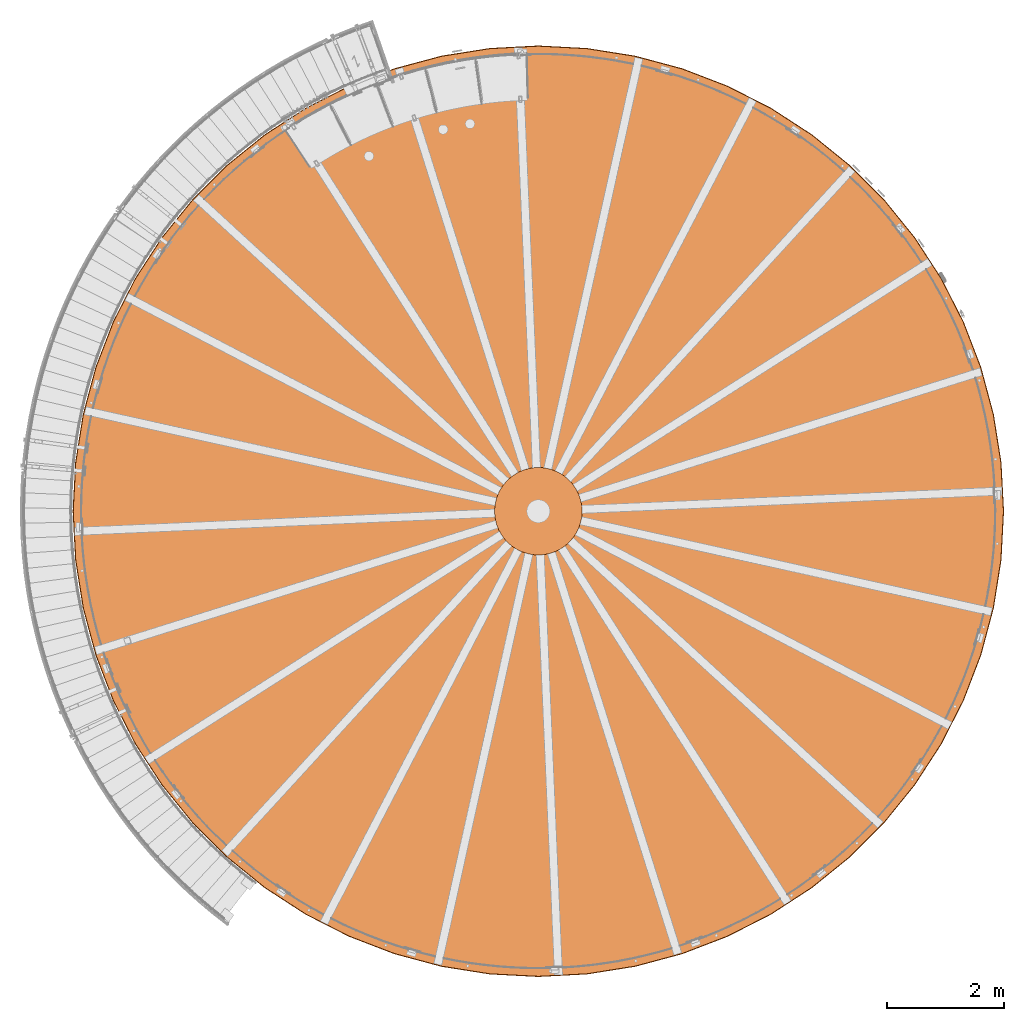
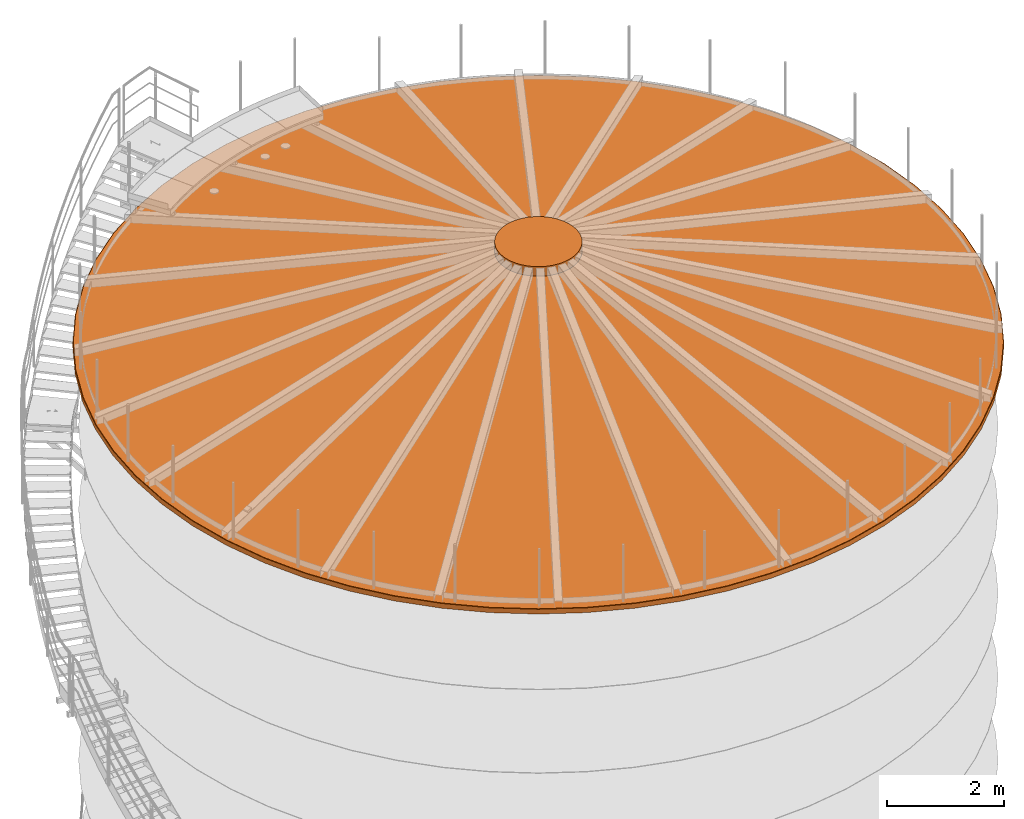
# One storey, part 21 of 126: 3 proxies.
"""IFC2X3 building model written with IfcOpenShell, lengths in millimetres."""

from ifc_helpers import new_model, si_unit, origin, origin_with_axes, place, context, project, spatial, faceted_brep, material, element, save


model = new_model("IFC2X3")

# Units and contexts
context_of_model_1 = context(None, 3, precision=0.1, world=origin())
context_of_model_2 = context(None, 3, precision=0.1, world=origin())
ifc_project = project(units=[si_unit("LENGTHUNIT", "METRE", prefix="MILLI"), si_unit("AREAUNIT", "SQUARE_METRE", prefix="CENTI"), si_unit("VOLUMEUNIT", "CUBIC_METRE", prefix="CENTI"), si_unit("MASSUNIT", "GRAM", prefix="KILO")], contexts=[context_of_model_1, context_of_model_2])

# Site, building, storey
site_placement = place(None, origin_with_axes())
site = spatial("IfcSite", under=ifc_project, at=site_placement, CompositionType="ELEMENT")
building_placement = place(site_placement, origin_with_axes())
building = spatial("IfcBuilding", under=site, at=building_placement, CompositionType="ELEMENT")
storey_placement = place(building_placement, origin_with_axes())
storey = spatial("IfcBuildingStorey", under=building, at=storey_placement, CompositionType="ELEMENT")

# Proxies
ifc_material = material(Name="STAHL")
proxy_1_placement = place(storey_placement, origin_with_axes())
element("IfcBuildingElementProxy", 1, at=proxy_1_placement, inside=storey, material=ifc_material, Name="profile", context=context_of_model_2, shape_type="Brep", body=[
    faceted_brep([(4017.5, 14911.6, 10506.0), (4761.3, 15290.5, 10506.0), (4761.3, 15290.5, 10494.0), (4017.5, 14911.6, 10494.0), (3317.4, 14456.9, 10506.0), (3317.4, 14456.9, 10494.0), (15936.3, 8838.6, 10506.0), (15980.0, 8005.0, 10506.0), (15980.0, 8005.0, 10494.0), (15936.3, 8838.6, 10494.0), (2668.7, 13931.6, 10506.0), (2668.7, 13931.6, 10494.0), (15805.7, 9663.1, 10506.0), (15805.7, 9663.1, 10494.0), (2078.4, 13341.3, 10506.0), (2078.4, 13341.3, 10494.0), (15589.7, 10469.4, 10506.0), (15589.7, 10469.4, 10494.0), (1553.1, 12692.6, 10506.0), (1553.1, 12692.6, 10494.0), (15290.5, 11248.7, 10506.0), (15290.5, 11248.7, 10494.0), (1098.4, 11992.5, 10506.0), (1098.4, 11992.5, 10494.0), (14911.6, 11992.5, 10506.0), (14911.6, 11992.5, 10494.0), (719.5, 11248.7, 10506.0), (719.5, 11248.7, 10494.0), (14456.9, 12692.6, 10506.0), (14456.9, 12692.6, 10494.0), (420.3, 10469.4, 10506.0), (420.3, 10469.4, 10494.0), (13931.6, 13341.3, 10506.0), (13931.6, 13341.3, 10494.0), (204.3, 9663.1, 10506.0), (204.3, 9663.1, 10494.0), (13341.3, 13931.6, 10506.0), (13341.3, 13931.6, 10494.0), (73.7, 8838.6, 10506.0), (73.7, 8838.6, 10494.0), (12692.6, 14456.9, 10506.0), (12692.6, 14456.9, 10494.0), (30.0, 8005.0, 10506.0), (30.0, 8005.0, 10494.0), (11992.5, 14911.6, 10506.0), (11992.5, 14911.6, 10494.0), (11248.7, 15290.5, 10506.0), (11248.7, 15290.5, 10494.0), (10469.4, 15589.7, 10506.0), (10469.4, 15589.7, 10494.0), (9663.1, 15805.7, 10506.0), (9663.1, 15805.7, 10494.0), (8838.6, 15936.3, 10506.0), (8838.6, 15936.3, 10494.0), (8005.0, 15980.0, 10506.0), (8005.0, 15980.0, 10494.0), (7171.4, 15936.3, 10506.0), (7171.4, 15936.3, 10494.0), (6346.9, 15805.7, 10506.0), (6346.9, 15805.7, 10494.0), (5540.6, 15589.7, 10506.0), (5540.6, 15589.7, 10494.0), (11907.5, 1245.7, 10506.0), (11907.5, 1245.7, 10494.0), (11179.6, 874.8, 10494.0), (11179.6, 874.8, 10506.0), (12592.7, 1690.6, 10506.0), (12592.7, 1690.6, 10494.0), (242.8, 7189.2, 10506.0), (242.8, 7189.2, 10494.0), (200.0, 8005.0, 10494.0), (200.0, 8005.0, 10506.0), (13227.6, 2204.8, 10506.0), (13227.6, 2204.8, 10494.0), (370.6, 6382.2, 10506.0), (370.6, 6382.2, 10494.0), (13805.2, 2782.4, 10506.0), (13805.2, 2782.4, 10494.0), (582.0, 5593.1, 10506.0), (582.0, 5593.1, 10494.0), (874.8, 4830.4, 10506.0), (874.8, 4830.4, 10494.0), (14319.4, 3417.3, 10506.0), (14319.4, 3417.3, 10494.0), (14764.3, 4102.5, 10506.0), (14764.3, 4102.5, 10494.0), (1245.7, 4102.5, 10506.0), (1245.7, 4102.5, 10494.0), (1690.6, 3417.3, 10506.0), (1690.6, 3417.3, 10494.0), (15135.2, 4830.4, 10506.0), (15135.2, 4830.4, 10494.0), (15428.0, 5593.1, 10506.0), (15428.0, 5593.1, 10494.0), (2204.8, 2782.4, 10506.0), (2204.8, 2782.4, 10494.0), (15639.4, 6382.2, 10506.0), (15639.4, 6382.2, 10494.0), (2782.4, 2204.8, 10506.0), (2782.4, 2204.8, 10494.0), (15767.2, 7189.2, 10506.0), (15767.2, 7189.2, 10494.0), (3417.3, 1690.6, 10506.0), (3417.3, 1690.6, 10494.0), (15810.0, 8005.0, 10506.0), (15810.0, 8005.0, 10494.0), (4102.5, 1245.7, 10506.0), (4102.5, 1245.7, 10494.0), (4830.4, 874.8, 10506.0), (4830.4, 874.8, 10494.0), (5593.1, 582.0, 10506.0), (5593.1, 582.0, 10494.0), (6382.2, 370.6, 10506.0), (6382.2, 370.6, 10494.0), (7189.2, 242.8, 10506.0), (7189.2, 242.8, 10494.0), (8005.0, 200.0, 10506.0), (8005.0, 200.0, 10494.0), (8820.8, 242.8, 10506.0), (8820.8, 242.8, 10494.0), (9627.8, 370.6, 10506.0), (9627.8, 370.6, 10494.0), (10416.9, 582.0, 10506.0), (10416.9, 582.0, 10494.0), (8005.0, 30.0, 10506.0), (8838.6, 73.7, 10506.0), (9663.1, 204.3, 10506.0), (10469.4, 420.3, 10506.0), (11248.7, 719.5, 10506.0), (11992.5, 1098.4, 10506.0), (12692.6, 1553.1, 10506.0), (13341.3, 2078.4, 10506.0), (13931.6, 2668.7, 10506.0), (14456.9, 3317.4, 10506.0), (14911.6, 4017.5, 10506.0), (15290.5, 4761.3, 10506.0), (15589.7, 5540.6, 10506.0), (15805.7, 6346.9, 10506.0), (15936.3, 7171.4, 10506.0), (73.7, 7171.4, 10506.0), (204.3, 6346.9, 10506.0), (420.3, 5540.6, 10506.0), (719.5, 4761.3, 10506.0), (1098.4, 4017.5, 10506.0), (1553.1, 3317.4, 10506.0), (2078.4, 2668.7, 10506.0), (242.8, 8820.8, 10506.0), (370.6, 9627.8, 10506.0), (582.0, 10416.9, 10506.0), (874.8, 11179.6, 10506.0), (1245.7, 11907.5, 10506.0), (1690.6, 12592.7, 10506.0), (2204.8, 13227.6, 10506.0), (2782.4, 13805.2, 10506.0), (3417.3, 14319.4, 10506.0), (4102.5, 14764.3, 10506.0), (4830.4, 15135.2, 10506.0), (5593.1, 15428.0, 10506.0), (6382.2, 15639.4, 10506.0), (7189.2, 15767.2, 10506.0), (8005.0, 15810.0, 10506.0), (8820.8, 15767.2, 10506.0), (9627.8, 15639.4, 10506.0), (10416.9, 15428.0, 10506.0), (11179.6, 15135.2, 10506.0), (11907.5, 14764.3, 10506.0), (12592.7, 14319.4, 10506.0), (13227.6, 13805.2, 10506.0), (13805.2, 13227.6, 10506.0), (14319.4, 12592.7, 10506.0), (14764.3, 11907.5, 10506.0), (15135.2, 11179.6, 10506.0), (15428.0, 10416.9, 10506.0), (15639.4, 9627.8, 10506.0), (15767.2, 8820.8, 10506.0), (2668.7, 2078.4, 10506.0), (3317.4, 1553.1, 10506.0), (4017.5, 1098.4, 10506.0), (4761.3, 719.5, 10506.0), (5540.6, 420.3, 10506.0), (6346.9, 204.3, 10506.0), (7171.4, 73.7, 10506.0), (4102.5, 14764.3, 10494.0), (4830.4, 15135.2, 10494.0), (3417.3, 14319.4, 10494.0), (15767.2, 8820.8, 10494.0), (15639.4, 9627.8, 10494.0), (2782.4, 13805.2, 10494.0), (2204.8, 13227.6, 10494.0), (15428.0, 10416.9, 10494.0), (15135.2, 11179.6, 10494.0), (1690.6, 12592.7, 10494.0), (1245.7, 11907.5, 10494.0), (14764.3, 11907.5, 10494.0), (874.8, 11179.6, 10494.0), (14319.4, 12592.7, 10494.0), (13805.2, 13227.6, 10494.0), (582.0, 10416.9, 10494.0), (370.6, 9627.8, 10494.0), (13227.6, 13805.2, 10494.0), (242.8, 8820.8, 10494.0), (12592.7, 14319.4, 10494.0), (11907.5, 14764.3, 10494.0), (11179.6, 15135.2, 10494.0), (10416.9, 15428.0, 10494.0), (9627.8, 15639.4, 10494.0), (8820.8, 15767.2, 10494.0), (8005.0, 15810.0, 10494.0), (7189.2, 15767.2, 10494.0), (6382.2, 15639.4, 10494.0), (5593.1, 15428.0, 10494.0), (8005.0, 30.0, 10494.0), (7171.4, 73.7, 10494.0), (6346.9, 204.3, 10494.0), (5540.6, 420.3, 10494.0), (4761.3, 719.5, 10494.0), (4017.5, 1098.4, 10494.0), (3317.4, 1553.1, 10494.0), (2668.7, 2078.4, 10494.0), (2078.4, 2668.7, 10494.0), (1553.1, 3317.4, 10494.0), (1098.4, 4017.5, 10494.0), (719.5, 4761.3, 10494.0), (420.3, 5540.6, 10494.0), (204.3, 6346.9, 10494.0), (73.7, 7171.4, 10494.0), (15936.3, 7171.4, 10494.0), (15805.7, 6346.9, 10494.0), (15589.7, 5540.6, 10494.0), (15290.5, 4761.3, 10494.0), (14911.6, 4017.5, 10494.0), (14456.9, 3317.4, 10494.0), (13931.6, 2668.7, 10494.0), (13341.3, 2078.4, 10494.0), (12692.6, 1553.1, 10494.0), (11992.5, 1098.4, 10494.0), (11248.7, 719.5, 10494.0), (10469.4, 420.3, 10494.0), (9663.1, 204.3, 10494.0), (8838.6, 73.7, 10494.0)], [[[0, 1, 2, 3]], [[4, 0, 3, 5]], [[6, 7, 8, 9]], [[10, 4, 5, 11]], [[12, 6, 9, 13]], [[14, 10, 11, 15]], [[16, 12, 13, 17]], [[18, 14, 15, 19]], [[20, 16, 17, 21]], [[22, 18, 19, 23]], [[24, 20, 21, 25]], [[26, 22, 23, 27]], [[28, 24, 25, 29]], [[30, 26, 27, 31]], [[32, 28, 29, 33]], [[34, 30, 31, 35]], [[36, 32, 33, 37]], [[38, 34, 35, 39]], [[40, 36, 37, 41]], [[42, 38, 39, 43]], [[44, 40, 41, 45]], [[46, 44, 45, 47]], [[48, 46, 47, 49]], [[50, 48, 49, 51]], [[52, 50, 51, 53]], [[54, 52, 53, 55]], [[56, 54, 55, 57]], [[58, 56, 57, 59]], [[60, 58, 59, 61]], [[1, 60, 61, 2]], [[62, 63, 64, 65]], [[66, 67, 63, 62]], [[68, 69, 70, 71]], [[72, 73, 67, 66]], [[74, 75, 69, 68]], [[76, 77, 73, 72]], [[78, 79, 75, 74]], [[78, 80, 81, 79]], [[82, 83, 77, 76]], [[84, 85, 83, 82]], [[86, 87, 81, 80]], [[86, 88, 89, 87]], [[90, 91, 85, 84]], [[92, 93, 91, 90]], [[94, 95, 89, 88]], [[96, 97, 93, 92]], [[98, 99, 95, 94]], [[100, 101, 97, 96]], [[102, 103, 99, 98]], [[104, 105, 101, 100]], [[106, 107, 103, 102]], [[108, 109, 107, 106]], [[110, 111, 109, 108]], [[112, 113, 111, 110]], [[114, 115, 113, 112]], [[116, 117, 115, 114]], [[118, 119, 117, 116]], [[120, 121, 119, 118]], [[122, 123, 121, 120]], [[65, 64, 123, 122]], [[124, 125, 126, 127, 128, 129, 130, 131, 132, 133, 134, 135, 136, 137, 138, 7, 6, 12, 16, 20, 24, 28, 32, 36, 40, 44, 46, 48, 50, 52, 54, 56, 58, 60, 1, 0, 4, 10, 14, 18, 22, 26, 30, 34, 38, 42, 139, 140, 141, 142, 143, 144, 145, 94, 88, 86, 80, 78, 74, 68, 71, 146, 147, 148, 149, 150, 151, 152, 153, 154, 155, 156, 157, 158, 159, 160, 161, 162, 163, 164, 165, 166, 167, 168, 169, 170, 171, 172, 173, 174, 104, 100, 96, 92, 90, 84, 82, 76, 72, 66, 62, 65, 122, 120, 118, 116, 114, 112, 110, 108, 106, 102, 98, 94, 145, 175, 176, 177, 178, 179, 180, 181]], [[155, 182, 183, 156]], [[154, 184, 182, 155]], [[174, 185, 105, 104]], [[174, 173, 186, 185]], [[153, 187, 184, 154]], [[152, 188, 187, 153]], [[172, 189, 186, 173]], [[172, 171, 190, 189]], [[151, 191, 188, 152]], [[150, 192, 191, 151]], [[170, 193, 190, 171]], [[149, 194, 192, 150]], [[169, 195, 193, 170]], [[169, 168, 196, 195]], [[148, 197, 194, 149]], [[147, 198, 197, 148]], [[167, 199, 196, 168]], [[146, 200, 198, 147]], [[166, 201, 199, 167]], [[71, 70, 200, 146]], [[165, 202, 201, 166]], [[164, 203, 202, 165]], [[163, 204, 203, 164]], [[162, 205, 204, 163]], [[161, 206, 205, 162]], [[160, 207, 206, 161]], [[159, 208, 207, 160]], [[158, 209, 208, 159]], [[157, 210, 209, 158]], [[156, 183, 210, 157]], [[211, 212, 213, 214, 215, 216, 217, 218, 219, 220, 221, 222, 223, 224, 225, 43, 39, 35, 31, 27, 23, 19, 15, 11, 5, 3, 2, 61, 59, 57, 55, 53, 51, 49, 47, 45, 41, 37, 33, 29, 25, 21, 17, 13, 9, 8, 226, 227, 228, 229, 230, 231, 232, 233, 77, 83, 85, 91, 93, 97, 101, 105, 185, 186, 189, 190, 193, 195, 196, 199, 201, 202, 203, 204, 205, 206, 207, 208, 209, 210, 183, 182, 184, 187, 188, 191, 192, 194, 197, 198, 200, 70, 69, 75, 79, 81, 87, 89, 95, 99, 103, 107, 109, 111, 113, 115, 117, 119, 121, 123, 64, 63, 67, 73, 77, 233, 234, 235, 236, 237, 238, 239]], [[128, 127, 237, 236]], [[129, 128, 236, 235]], [[130, 129, 235, 234]], [[139, 42, 43, 225]], [[131, 130, 234, 233]], [[140, 139, 225, 224]], [[132, 131, 233, 232]], [[141, 140, 224, 223]], [[133, 132, 232, 231]], [[142, 141, 223, 222]], [[134, 133, 231, 230]], [[143, 142, 222, 221]], [[135, 134, 230, 229]], [[144, 143, 221, 220]], [[136, 135, 229, 228]], [[145, 144, 220, 219]], [[137, 136, 228, 227]], [[175, 145, 219, 218]], [[138, 137, 227, 226]], [[176, 175, 218, 217]], [[7, 138, 226, 8]], [[177, 176, 217, 216]], [[178, 177, 216, 215]], [[179, 178, 215, 214]], [[180, 179, 214, 213]], [[181, 180, 213, 212]], [[124, 181, 212, 211]], [[125, 124, 211, 239]], [[126, 125, 239, 238]], [[127, 126, 238, 237]]]),
])
proxy_2_placement = place(storey_placement, origin_with_axes())
element("IfcBuildingElementProxy", 2, at=proxy_2_placement, inside=storey, material=ifc_material, Name="profile", context=context_of_model_2, shape_type="Brep", body=[
    faceted_brep([(4012.5, 14920.2, 10502.0), (4757.2, 15299.7, 10502.0), (4757.2, 15299.7, 10402.0), (4012.5, 14920.2, 10402.0), (3311.5, 14465.0, 10502.0), (3311.5, 14465.0, 10402.0), (15946.3, 8839.7, 10502.0), (15990.0, 8005.0, 10502.0), (15990.0, 8005.0, 10402.0), (15946.3, 8839.7, 10402.0), (2662.0, 13939.0, 10502.0), (2662.0, 13939.0, 10402.0), (15815.5, 9665.2, 10502.0), (15815.5, 9665.2, 10402.0), (2071.0, 13348.0, 10502.0), (2071.0, 13348.0, 10402.0), (15599.2, 10472.5, 10502.0), (15599.2, 10472.5, 10402.0), (1545.0, 12698.5, 10502.0), (1545.0, 12698.5, 10402.0), (15299.7, 11252.8, 10502.0), (15299.7, 11252.8, 10402.0), (1089.8, 11997.5, 10502.0), (1089.8, 11997.5, 10402.0), (14920.2, 11997.5, 10502.0), (14920.2, 11997.5, 10402.0), (710.3, 11252.8, 10502.0), (710.3, 11252.8, 10402.0), (14465.0, 12698.5, 10502.0), (14465.0, 12698.5, 10402.0), (410.8, 10472.5, 10502.0), (410.8, 10472.5, 10402.0), (13939.0, 13348.0, 10502.0), (13939.0, 13348.0, 10402.0), (194.5, 9665.2, 10502.0), (194.5, 9665.2, 10402.0), (13348.0, 13939.0, 10502.0), (13348.0, 13939.0, 10402.0), (63.7, 8839.7, 10502.0), (63.7, 8839.7, 10402.0), (12698.5, 14465.0, 10502.0), (12698.5, 14465.0, 10402.0), (20.0, 8005.0, 10502.0), (20.0, 8005.0, 10402.0), (11997.5, 14920.2, 10502.0), (11997.5, 14920.2, 10402.0), (11252.8, 15299.7, 10502.0), (11252.8, 15299.7, 10402.0), (10472.5, 15599.2, 10502.0), (10472.5, 15599.2, 10402.0), (9665.2, 15815.5, 10502.0), (9665.2, 15815.5, 10402.0), (8839.7, 15946.3, 10502.0), (8839.7, 15946.3, 10402.0), (8005.0, 15990.0, 10402.0), (8005.0, 15990.0, 10502.0), (7170.3, 15946.3, 10502.0), (7170.3, 15946.3, 10402.0), (6344.8, 15815.5, 10502.0), (6344.8, 15815.5, 10402.0), (5537.5, 15599.2, 10502.0), (5537.5, 15599.2, 10402.0), (11992.5, 1098.4, 10502.0), (11992.5, 1098.4, 10402.0), (11248.7, 719.5, 10402.0), (11248.7, 719.5, 10502.0), (30.0, 8005.0, 10502.0), (73.7, 7171.4, 10502.0), (73.7, 7171.4, 10402.0), (30.0, 8005.0, 10402.0), (12692.6, 1553.1, 10502.0), (12692.6, 1553.1, 10402.0), (13341.3, 2078.4, 10502.0), (13341.3, 2078.4, 10402.0), (204.3, 6346.9, 10502.0), (204.3, 6346.9, 10402.0), (13931.6, 2668.7, 10502.0), (13931.6, 2668.7, 10402.0), (420.3, 5540.6, 10502.0), (420.3, 5540.6, 10402.0), (719.5, 4761.3, 10502.0), (719.5, 4761.3, 10402.0), (14456.9, 3317.4, 10502.0), (14456.9, 3317.4, 10402.0), (14911.6, 4017.5, 10502.0), (14911.6, 4017.5, 10402.0), (1098.4, 4017.5, 10502.0), (1098.4, 4017.5, 10402.0), (15290.5, 4761.3, 10502.0), (15290.5, 4761.3, 10402.0), (1553.1, 3317.4, 10502.0), (1553.1, 3317.4, 10402.0), (15589.7, 5540.6, 10502.0), (15589.7, 5540.6, 10402.0), (2078.4, 2668.7, 10502.0), (2078.4, 2668.7, 10402.0), (15805.7, 6346.9, 10502.0), (15805.7, 6346.9, 10402.0), (2668.7, 2078.4, 10502.0), (2668.7, 2078.4, 10402.0), (15936.3, 7171.4, 10502.0), (15936.3, 7171.4, 10402.0), (3317.4, 1553.1, 10502.0), (3317.4, 1553.1, 10402.0), (15980.0, 8005.0, 10502.0), (15980.0, 8005.0, 10402.0), (4017.5, 1098.4, 10502.0), (4017.5, 1098.4, 10402.0), (4761.3, 719.5, 10502.0), (4761.3, 719.5, 10402.0), (5540.6, 420.3, 10502.0), (5540.6, 420.3, 10402.0), (6346.9, 204.3, 10502.0), (6346.9, 204.3, 10402.0), (7171.4, 73.7, 10502.0), (7171.4, 73.7, 10402.0), (8005.0, 30.0, 10502.0), (8005.0, 30.0, 10402.0), (8838.6, 73.7, 10502.0), (8838.6, 73.7, 10402.0), (9663.1, 204.3, 10502.0), (9663.1, 204.3, 10402.0), (10469.4, 420.3, 10502.0), (10469.4, 420.3, 10402.0), (4761.3, 15290.5, 10502.0), (4761.3, 15290.5, 10402.0), (5540.6, 15589.7, 10402.0), (5540.6, 15589.7, 10502.0), (4017.5, 14911.6, 10502.0), (4017.5, 14911.6, 10402.0), (3317.4, 14456.9, 10502.0), (3317.4, 14456.9, 10402.0), (15936.3, 8838.6, 10502.0), (15936.3, 8838.6, 10402.0), (2668.7, 13931.6, 10502.0), (2668.7, 13931.6, 10402.0), (15805.7, 9663.1, 10502.0), (15805.7, 9663.1, 10402.0), (2078.4, 13341.3, 10502.0), (2078.4, 13341.3, 10402.0), (15589.7, 10469.4, 10502.0), (15589.7, 10469.4, 10402.0), (1553.1, 12692.6, 10502.0), (1553.1, 12692.6, 10402.0), (15290.5, 11248.7, 10502.0), (15290.5, 11248.7, 10402.0), (1098.4, 11992.5, 10502.0), (1098.4, 11992.5, 10402.0), (14911.6, 11992.5, 10502.0), (14911.6, 11992.5, 10402.0), (719.5, 11248.7, 10502.0), (719.5, 11248.7, 10402.0), (14456.9, 12692.6, 10502.0), (14456.9, 12692.6, 10402.0), (420.3, 10469.4, 10502.0), (420.3, 10469.4, 10402.0), (13931.6, 13341.3, 10502.0), (13931.6, 13341.3, 10402.0), (204.3, 9663.1, 10502.0), (204.3, 9663.1, 10402.0), (13341.3, 13931.6, 10502.0), (13341.3, 13931.6, 10402.0), (73.7, 8838.6, 10502.0), (73.7, 8838.6, 10402.0), (12692.6, 14456.9, 10502.0), (12692.6, 14456.9, 10402.0), (11992.5, 14911.6, 10502.0), (11992.5, 14911.6, 10402.0), (11248.7, 15290.5, 10502.0), (11248.7, 15290.5, 10402.0), (10469.4, 15589.7, 10502.0), (10469.4, 15589.7, 10402.0), (9663.1, 15805.7, 10502.0), (9663.1, 15805.7, 10402.0), (8838.6, 15936.3, 10502.0), (8838.6, 15936.3, 10402.0), (8005.0, 15980.0, 10502.0), (8005.0, 15980.0, 10402.0), (7171.4, 15936.3, 10502.0), (7171.4, 15936.3, 10402.0), (6346.9, 15805.7, 10502.0), (6346.9, 15805.7, 10402.0), (8005.0, 20.0, 10402.0), (7170.3, 63.7, 10402.0), (6344.8, 194.5, 10402.0), (5537.5, 410.8, 10402.0), (4757.2, 710.3, 10402.0), (4012.5, 1089.8, 10402.0), (3311.5, 1545.0, 10402.0), (2662.0, 2071.0, 10402.0), (2071.0, 2662.0, 10402.0), (1545.0, 3311.5, 10402.0), (1089.8, 4012.5, 10402.0), (710.3, 4757.2, 10402.0), (410.8, 5537.5, 10402.0), (194.5, 6344.8, 10402.0), (63.7, 7170.3, 10402.0), (15946.3, 7170.3, 10402.0), (15815.5, 6344.8, 10402.0), (15599.2, 5537.5, 10402.0), (15299.7, 4757.2, 10402.0), (14920.2, 4012.5, 10402.0), (14465.0, 3311.5, 10402.0), (13939.0, 2662.0, 10402.0), (13348.0, 2071.0, 10402.0), (12698.5, 1545.0, 10402.0), (11997.5, 1089.8, 10402.0), (11252.8, 710.3, 10402.0), (10472.5, 410.8, 10402.0), (9665.2, 194.5, 10402.0), (8839.7, 63.7, 10402.0), (11997.5, 1089.8, 10502.0), (11252.8, 710.3, 10502.0), (63.7, 7170.3, 10502.0), (12698.5, 1545.0, 10502.0), (194.5, 6344.8, 10502.0), (13348.0, 2071.0, 10502.0), (13939.0, 2662.0, 10502.0), (410.8, 5537.5, 10502.0), (710.3, 4757.2, 10502.0), (14465.0, 3311.5, 10502.0), (14920.2, 4012.5, 10502.0), (1089.8, 4012.5, 10502.0), (15299.7, 4757.2, 10502.0), (1545.0, 3311.5, 10502.0), (15599.2, 5537.5, 10502.0), (2071.0, 2662.0, 10502.0), (15815.5, 6344.8, 10502.0), (15946.3, 7170.3, 10502.0), (2662.0, 2071.0, 10502.0), (3311.5, 1545.0, 10502.0), (4012.5, 1089.8, 10502.0), (4757.2, 710.3, 10502.0), (5537.5, 410.8, 10502.0), (6344.8, 194.5, 10502.0), (7170.3, 63.7, 10502.0), (8005.0, 20.0, 10502.0), (8839.7, 63.7, 10502.0), (9665.2, 194.5, 10502.0), (10472.5, 410.8, 10502.0)], [[[0, 1, 2, 3]], [[4, 0, 3, 5]], [[6, 7, 8, 9]], [[10, 4, 5, 11]], [[12, 6, 9, 13]], [[14, 10, 11, 15]], [[16, 12, 13, 17]], [[18, 14, 15, 19]], [[20, 16, 17, 21]], [[22, 18, 19, 23]], [[24, 20, 21, 25]], [[26, 22, 23, 27]], [[28, 24, 25, 29]], [[30, 26, 27, 31]], [[32, 28, 29, 33]], [[34, 30, 31, 35]], [[36, 32, 33, 37]], [[38, 34, 35, 39]], [[40, 36, 37, 41]], [[42, 38, 39, 43]], [[44, 40, 41, 45]], [[46, 44, 45, 47]], [[48, 46, 47, 49]], [[50, 48, 49, 51]], [[52, 50, 51, 53]], [[52, 53, 54, 55]], [[56, 55, 54, 57]], [[58, 56, 57, 59]], [[60, 58, 59, 61]], [[1, 60, 61, 2]], [[62, 63, 64, 65]], [[66, 67, 68, 69]], [[70, 71, 63, 62]], [[72, 73, 71, 70]], [[74, 75, 68, 67]], [[76, 77, 73, 72]], [[78, 79, 75, 74]], [[78, 80, 81, 79]], [[82, 83, 77, 76]], [[84, 85, 83, 82]], [[86, 87, 81, 80]], [[88, 89, 85, 84]], [[90, 91, 87, 86]], [[92, 93, 89, 88]], [[94, 95, 91, 90]], [[96, 97, 93, 92]], [[98, 99, 95, 94]], [[100, 101, 97, 96]], [[102, 103, 99, 98]], [[104, 105, 101, 100]], [[106, 107, 103, 102]], [[108, 109, 107, 106]], [[110, 111, 109, 108]], [[112, 113, 111, 110]], [[114, 115, 113, 112]], [[116, 117, 115, 114]], [[118, 119, 117, 116]], [[120, 121, 119, 118]], [[122, 123, 121, 120]], [[65, 64, 123, 122]], [[124, 125, 126, 127]], [[128, 129, 125, 124]], [[130, 131, 129, 128]], [[132, 133, 105, 104]], [[134, 135, 131, 130]], [[136, 137, 133, 132]], [[138, 139, 135, 134]], [[140, 141, 137, 136]], [[142, 143, 139, 138]], [[144, 145, 141, 140]], [[146, 147, 143, 142]], [[148, 149, 145, 144]], [[150, 151, 147, 146]], [[152, 153, 149, 148]], [[154, 155, 151, 150]], [[156, 157, 153, 152]], [[158, 159, 155, 154]], [[160, 161, 157, 156]], [[162, 163, 159, 158]], [[164, 165, 161, 160]], [[66, 69, 163, 162]], [[166, 167, 165, 164]], [[168, 169, 167, 166]], [[170, 171, 169, 168]], [[172, 173, 171, 170]], [[174, 175, 173, 172]], [[176, 177, 175, 174]], [[178, 179, 177, 176]], [[180, 181, 179, 178]], [[127, 126, 181, 180]], [[182, 183, 184, 185, 186, 187, 188, 189, 190, 191, 192, 193, 194, 195, 196, 43, 39, 35, 31, 27, 23, 19, 15, 11, 5, 3, 2, 61, 59, 57, 54, 53, 51, 49, 47, 45, 41, 37, 33, 29, 25, 21, 17, 13, 9, 8, 197, 198, 199, 200, 201, 202, 203, 204, 77, 83, 85, 89, 93, 97, 101, 105, 133, 137, 141, 145, 149, 153, 157, 161, 165, 167, 169, 171, 173, 175, 177, 179, 181, 126, 125, 129, 131, 135, 139, 143, 147, 151, 155, 159, 163, 69, 68, 75, 79, 81, 87, 91, 95, 99, 103, 107, 109, 111, 113, 115, 117, 119, 121, 123, 64, 63, 71, 73, 77, 204, 205, 206, 207, 208, 209, 210]], [[211, 212, 207, 206]], [[42, 43, 196, 213]], [[214, 211, 206, 205]], [[213, 196, 195, 215]], [[216, 214, 205, 204]], [[217, 216, 204, 203]], [[218, 215, 195, 194]], [[218, 194, 193, 219]], [[220, 217, 203, 202]], [[221, 220, 202, 201]], [[222, 219, 193, 192]], [[223, 221, 201, 200]], [[224, 222, 192, 191]], [[225, 223, 200, 199]], [[226, 224, 191, 190]], [[227, 225, 199, 198]], [[228, 227, 198, 197]], [[229, 226, 190, 189]], [[228, 197, 8, 7]], [[229, 189, 188, 230]], [[230, 188, 187, 231]], [[232, 231, 187, 186]], [[232, 186, 185, 233]], [[233, 185, 184, 234]], [[234, 184, 183, 235]], [[236, 235, 183, 182]], [[237, 236, 182, 210]], [[238, 237, 210, 209]], [[239, 238, 209, 208]], [[212, 239, 208, 207]], [[236, 237, 238, 239, 212, 211, 214, 216, 217, 220, 221, 223, 225, 227, 228, 7, 6, 12, 16, 20, 24, 28, 32, 36, 40, 44, 46, 48, 50, 52, 55, 56, 58, 60, 1, 0, 4, 10, 14, 18, 22, 26, 30, 34, 38, 42, 213, 215, 218, 219, 222, 224, 226, 229, 94, 90, 86, 80, 78, 74, 67, 66, 162, 158, 154, 150, 146, 142, 138, 134, 130, 128, 124, 127, 180, 178, 176, 174, 172, 170, 168, 166, 164, 160, 156, 152, 148, 144, 140, 136, 132, 104, 100, 96, 92, 88, 84, 82, 76, 72, 70, 62, 65, 122, 120, 118, 116, 114, 112, 110, 108, 106, 102, 98, 94, 229, 230, 231, 232, 233, 234, 235]]]),
])
proxy_3_placement = place(storey_placement, origin_with_axes())
element("IfcBuildingElementProxy", 3, at=proxy_3_placement, inside=storey, material=ifc_material, Name="profile", context=context_of_model_2, shape_type="Brep", body=[
    faceted_brep([(7630.0, 8654.5, 12607.9), (7699.9, 8690.2, 12607.9), (7699.9, 8690.2, 12407.9), (7630.0, 8654.5, 12407.9), (7564.2, 8611.8, 12407.9), (7564.2, 8611.8, 12607.9), (7503.2, 8562.4, 12407.9), (7503.2, 8562.4, 12607.9), (8750.9, 8083.4, 12607.9), (8755.0, 8005.0, 12607.9), (8755.0, 8005.0, 12407.9), (8750.9, 8083.4, 12407.9), (7447.6, 8506.8, 12407.9), (7447.6, 8506.8, 12607.9), (7398.2, 8445.8, 12407.9), (7398.2, 8445.8, 12607.9), (8738.6, 8160.9, 12607.9), (8738.6, 8160.9, 12407.9), (7355.5, 8380.0, 12407.9), (7355.5, 8380.0, 12607.9), (8718.3, 8236.8, 12607.9), (8718.3, 8236.8, 12407.9), (8690.2, 8310.1, 12407.9), (8690.2, 8310.1, 12607.9), (7319.8, 8310.1, 12607.9), (7319.8, 8310.1, 12407.9), (7291.7, 8236.8, 12407.9), (7291.7, 8236.8, 12607.9), (8654.5, 8380.0, 12607.9), (8654.5, 8380.0, 12407.9), (7271.4, 8160.9, 12407.9), (7271.4, 8160.9, 12607.9), (8611.8, 8445.8, 12607.9), (8611.8, 8445.8, 12407.9), (7259.1, 8083.4, 12407.9), (7259.1, 8083.4, 12607.9), (8562.4, 8506.8, 12607.9), (8562.4, 8506.8, 12407.9), (8506.8, 8562.4, 12407.9), (8506.8, 8562.4, 12607.9), (7255.0, 8005.0, 12607.9), (7255.0, 8005.0, 12407.9), (8445.8, 8611.8, 12607.9), (8445.8, 8611.8, 12407.9), (8380.0, 8654.5, 12607.9), (8380.0, 8654.5, 12407.9), (8310.1, 8690.2, 12407.9), (8310.1, 8690.2, 12607.9), (8236.8, 8718.3, 12607.9), (8236.8, 8718.3, 12407.9), (8160.9, 8738.6, 12607.9), (8160.9, 8738.6, 12407.9), (8083.4, 8750.9, 12607.9), (8083.4, 8750.9, 12407.9), (8005.0, 8755.0, 12607.9), (8005.0, 8755.0, 12407.9), (7926.6, 8750.9, 12407.9), (7926.6, 8750.9, 12607.9), (7849.1, 8738.6, 12407.9), (7849.1, 8738.6, 12607.9), (7773.2, 8718.3, 12607.9), (7773.2, 8718.3, 12407.9), (8306.0, 7329.0, 12607.9), (8306.0, 7329.0, 12407.9), (8233.7, 7301.2, 12407.9), (8233.7, 7301.2, 12607.9), (8375.0, 7364.1, 12607.9), (8375.0, 7364.1, 12407.9), (8440.0, 7406.3, 12607.9), (8440.0, 7406.3, 12407.9), (7269.1, 7927.6, 12607.9), (7269.1, 7927.6, 12407.9), (7265.0, 8005.0, 12407.9), (7265.0, 8005.0, 12607.9), (8500.2, 7455.1, 12607.9), (8500.2, 7455.1, 12407.9), (7281.2, 7851.1, 12607.9), (7281.2, 7851.1, 12407.9), (8554.9, 7509.8, 12607.9), (8554.9, 7509.8, 12407.9), (7301.2, 7776.3, 12607.9), (7301.2, 7776.3, 12407.9), (8603.7, 7570.0, 12607.9), (8603.7, 7570.0, 12407.9), (7329.0, 7704.0, 12607.9), (7329.0, 7704.0, 12407.9), (8645.9, 7635.0, 12607.9), (8645.9, 7635.0, 12407.9), (7364.1, 7635.0, 12607.9), (7364.1, 7635.0, 12407.9), (8681.0, 7704.0, 12607.9), (8681.0, 7704.0, 12407.9), (7406.3, 7570.0, 12607.9), (7406.3, 7570.0, 12407.9), (8708.8, 7776.3, 12607.9), (8708.8, 7776.3, 12407.9), (7455.1, 7509.8, 12607.9), (7455.1, 7509.8, 12407.9), (8728.8, 7851.1, 12607.9), (8728.8, 7851.1, 12407.9), (7509.8, 7455.1, 12607.9), (7509.8, 7455.1, 12407.9), (8740.9, 7927.6, 12607.9), (8740.9, 7927.6, 12407.9), (7570.0, 7406.3, 12607.9), (7570.0, 7406.3, 12407.9), (8745.0, 8005.0, 12607.9), (8745.0, 8005.0, 12407.9), (7635.0, 7364.1, 12607.9), (7635.0, 7364.1, 12407.9), (7704.0, 7329.0, 12607.9), (7704.0, 7329.0, 12407.9), (7776.3, 7301.2, 12607.9), (7776.3, 7301.2, 12407.9), (7851.1, 7281.2, 12607.9), (7851.1, 7281.2, 12407.9), (7927.6, 7269.1, 12607.9), (7927.6, 7269.1, 12407.9), (8005.0, 7265.0, 12607.9), (8005.0, 7265.0, 12407.9), (8082.4, 7269.1, 12607.9), (8082.4, 7269.1, 12407.9), (8158.9, 7281.2, 12607.9), (8158.9, 7281.2, 12407.9), (7635.0, 8645.9, 12607.9), (7635.0, 8645.9, 12407.9), (7704.0, 8681.0, 12407.9), (7704.0, 8681.0, 12607.9), (8740.9, 8082.4, 12607.9), (8740.9, 8082.4, 12407.9), (7570.0, 8603.7, 12607.9), (7570.0, 8603.7, 12407.9), (8728.8, 8158.9, 12607.9), (8728.8, 8158.9, 12407.9), (7509.8, 8554.9, 12607.9), (7509.8, 8554.9, 12407.9), (7455.1, 8500.2, 12607.9), (7455.1, 8500.2, 12407.9), (8708.8, 8233.7, 12607.9), (8708.8, 8233.7, 12407.9), (7406.3, 8440.0, 12607.9), (7406.3, 8440.0, 12407.9), (8681.0, 8306.0, 12607.9), (8681.0, 8306.0, 12407.9), (7364.1, 8375.0, 12607.9), (7364.1, 8375.0, 12407.9), (8645.9, 8375.0, 12607.9), (8645.9, 8375.0, 12407.9), (7329.0, 8306.0, 12607.9), (7329.0, 8306.0, 12407.9), (8603.7, 8440.0, 12607.9), (8603.7, 8440.0, 12407.9), (7301.2, 8233.7, 12607.9), (7301.2, 8233.7, 12407.9), (8554.9, 8500.2, 12607.9), (8554.9, 8500.2, 12407.9), (7281.2, 8158.9, 12607.9), (7281.2, 8158.9, 12407.9), (8500.2, 8554.9, 12607.9), (8500.2, 8554.9, 12407.9), (7269.1, 8082.4, 12607.9), (7269.1, 8082.4, 12407.9), (8440.0, 8603.7, 12607.9), (8440.0, 8603.7, 12407.9), (8375.0, 8645.9, 12607.9), (8375.0, 8645.9, 12407.9), (8306.0, 8681.0, 12607.9), (8306.0, 8681.0, 12407.9), (8233.7, 8708.8, 12607.9), (8233.7, 8708.8, 12407.9), (8158.9, 8728.8, 12607.9), (8158.9, 8728.8, 12407.9), (8082.4, 8740.9, 12607.9), (8082.4, 8740.9, 12407.9), (8005.0, 8745.0, 12607.9), (8005.0, 8745.0, 12407.9), (7927.6, 8740.9, 12607.9), (7927.6, 8740.9, 12407.9), (7851.1, 8728.8, 12607.9), (7851.1, 8728.8, 12407.9), (7776.3, 8708.8, 12607.9), (7776.3, 8708.8, 12407.9), (8005.0, 7255.0, 12407.9), (7926.6, 7259.1, 12407.9), (7849.1, 7271.4, 12407.9), (7773.2, 7291.7, 12407.9), (7699.9, 7319.8, 12407.9), (7630.0, 7355.5, 12407.9), (7564.2, 7398.2, 12407.9), (7503.2, 7447.6, 12407.9), (7447.6, 7503.2, 12407.9), (7398.2, 7564.2, 12407.9), (7355.5, 7630.0, 12407.9), (7319.8, 7699.9, 12407.9), (7291.7, 7773.2, 12407.9), (7271.4, 7849.1, 12407.9), (7259.1, 7926.6, 12407.9), (8750.9, 7926.6, 12407.9), (8738.6, 7849.1, 12407.9), (8718.3, 7773.2, 12407.9), (8690.2, 7699.9, 12407.9), (8654.5, 7630.0, 12407.9), (8611.8, 7564.2, 12407.9), (8562.4, 7503.2, 12407.9), (8506.8, 7447.6, 12407.9), (8445.8, 7398.2, 12407.9), (8380.0, 7355.5, 12407.9), (8310.1, 7319.8, 12407.9), (8236.8, 7291.7, 12407.9), (8160.9, 7271.4, 12407.9), (8083.4, 7259.1, 12407.9), (8380.0, 7355.5, 12607.9), (8310.1, 7319.8, 12607.9), (8445.8, 7398.2, 12607.9), (7259.1, 7926.6, 12607.9), (8506.8, 7447.6, 12607.9), (7271.4, 7849.1, 12607.9), (8562.4, 7503.2, 12607.9), (8611.8, 7564.2, 12607.9), (7291.7, 7773.2, 12607.9), (7319.8, 7699.9, 12607.9), (8654.5, 7630.0, 12607.9), (7355.5, 7630.0, 12607.9), (7398.2, 7564.2, 12607.9), (8690.2, 7699.9, 12607.9), (8718.3, 7773.2, 12607.9), (7447.6, 7503.2, 12607.9), (7503.2, 7447.6, 12607.9), (8738.6, 7849.1, 12607.9), (8750.9, 7926.6, 12607.9), (7564.2, 7398.2, 12607.9), (7630.0, 7355.5, 12607.9), (7699.9, 7319.8, 12607.9), (7773.2, 7291.7, 12607.9), (7849.1, 7271.4, 12607.9), (7926.6, 7259.1, 12607.9), (8005.0, 7255.0, 12607.9), (8083.4, 7259.1, 12607.9), (8160.9, 7271.4, 12607.9), (8236.8, 7291.7, 12607.9)], [[[0, 1, 2, 3]], [[0, 3, 4, 5]], [[5, 4, 6, 7]], [[8, 9, 10, 11]], [[7, 6, 12, 13]], [[13, 12, 14, 15]], [[16, 8, 11, 17]], [[15, 14, 18, 19]], [[20, 16, 17, 21]], [[20, 21, 22, 23]], [[24, 19, 18, 25]], [[24, 25, 26, 27]], [[28, 23, 22, 29]], [[27, 26, 30, 31]], [[32, 28, 29, 33]], [[31, 30, 34, 35]], [[36, 32, 33, 37]], [[36, 37, 38, 39]], [[40, 35, 34, 41]], [[42, 39, 38, 43]], [[44, 42, 43, 45]], [[44, 45, 46, 47]], [[48, 47, 46, 49]], [[50, 48, 49, 51]], [[52, 50, 51, 53]], [[54, 52, 53, 55]], [[54, 55, 56, 57]], [[57, 56, 58, 59]], [[60, 59, 58, 61]], [[60, 61, 2, 1]], [[62, 63, 64, 65]], [[66, 67, 63, 62]], [[68, 69, 67, 66]], [[70, 71, 72, 73]], [[74, 75, 69, 68]], [[76, 77, 71, 70]], [[78, 79, 75, 74]], [[80, 81, 77, 76]], [[82, 83, 79, 78]], [[84, 85, 81, 80]], [[86, 87, 83, 82]], [[88, 89, 85, 84]], [[90, 91, 87, 86]], [[92, 93, 89, 88]], [[94, 95, 91, 90]], [[96, 97, 93, 92]], [[98, 99, 95, 94]], [[100, 101, 97, 96]], [[102, 103, 99, 98]], [[104, 105, 101, 100]], [[106, 107, 103, 102]], [[108, 109, 105, 104]], [[110, 111, 109, 108]], [[112, 113, 111, 110]], [[114, 115, 113, 112]], [[116, 117, 115, 114]], [[118, 119, 117, 116]], [[120, 121, 119, 118]], [[122, 123, 121, 120]], [[65, 64, 123, 122]], [[124, 125, 126, 127]], [[106, 128, 129, 107]], [[130, 131, 125, 124]], [[128, 132, 133, 129]], [[134, 135, 131, 130]], [[136, 137, 135, 134]], [[138, 139, 133, 132]], [[140, 141, 137, 136]], [[142, 143, 139, 138]], [[144, 145, 141, 140]], [[146, 147, 143, 142]], [[148, 149, 145, 144]], [[150, 151, 147, 146]], [[152, 153, 149, 148]], [[154, 155, 151, 150]], [[156, 157, 153, 152]], [[158, 159, 155, 154]], [[160, 161, 157, 156]], [[162, 163, 159, 158]], [[73, 72, 161, 160]], [[164, 165, 163, 162]], [[166, 167, 165, 164]], [[168, 169, 167, 166]], [[170, 171, 169, 168]], [[172, 173, 171, 170]], [[174, 175, 173, 172]], [[176, 177, 175, 174]], [[178, 179, 177, 176]], [[180, 181, 179, 178]], [[127, 126, 181, 180]], [[182, 183, 184, 185, 186, 187, 188, 189, 190, 191, 192, 193, 194, 195, 196, 41, 34, 30, 26, 25, 18, 14, 12, 6, 4, 3, 2, 61, 58, 56, 55, 53, 51, 49, 46, 45, 43, 38, 37, 33, 29, 22, 21, 17, 11, 10, 197, 198, 199, 200, 201, 202, 203, 204, 79, 83, 87, 91, 95, 99, 103, 107, 129, 133, 139, 143, 147, 151, 155, 159, 163, 165, 167, 169, 171, 173, 175, 177, 179, 181, 126, 125, 131, 135, 137, 141, 145, 149, 153, 157, 161, 72, 71, 77, 81, 85, 89, 93, 97, 101, 105, 109, 111, 113, 115, 117, 119, 121, 123, 64, 63, 67, 69, 75, 79, 204, 205, 206, 207, 208, 209, 210]], [[211, 212, 207, 206]], [[213, 211, 206, 205]], [[214, 40, 41, 196]], [[215, 213, 205, 204]], [[216, 214, 196, 195]], [[217, 215, 204, 203]], [[217, 203, 202, 218]], [[219, 216, 195, 194]], [[220, 219, 194, 193]], [[221, 218, 202, 201]], [[222, 220, 193, 192]], [[222, 192, 191, 223]], [[224, 221, 201, 200]], [[225, 224, 200, 199]], [[226, 223, 191, 190]], [[226, 190, 189, 227]], [[228, 225, 199, 198]], [[228, 198, 197, 229]], [[229, 197, 10, 9]], [[230, 227, 189, 188]], [[231, 230, 188, 187]], [[232, 231, 187, 186]], [[233, 232, 186, 185]], [[234, 233, 185, 184]], [[235, 234, 184, 183]], [[236, 235, 183, 182]], [[236, 182, 210, 237]], [[238, 237, 210, 209]], [[239, 238, 209, 208]], [[212, 239, 208, 207]], [[236, 237, 238, 239, 212, 211, 213, 215, 217, 218, 221, 224, 225, 228, 229, 9, 8, 16, 20, 23, 28, 32, 36, 39, 42, 44, 47, 48, 50, 52, 54, 57, 59, 60, 1, 0, 5, 7, 13, 15, 19, 24, 27, 31, 35, 40, 214, 216, 219, 220, 222, 223, 226, 96, 92, 88, 84, 80, 76, 70, 73, 160, 156, 152, 148, 144, 140, 136, 134, 130, 124, 127, 180, 178, 176, 174, 172, 170, 168, 166, 164, 162, 158, 154, 150, 146, 142, 138, 132, 128, 106, 102, 98, 94, 90, 86, 82, 78, 74, 68, 66, 62, 65, 122, 120, 118, 116, 114, 112, 110, 108, 104, 100, 96, 226, 227, 230, 231, 232, 233, 234, 235]]]),
])

save(model, "model.ifc")
